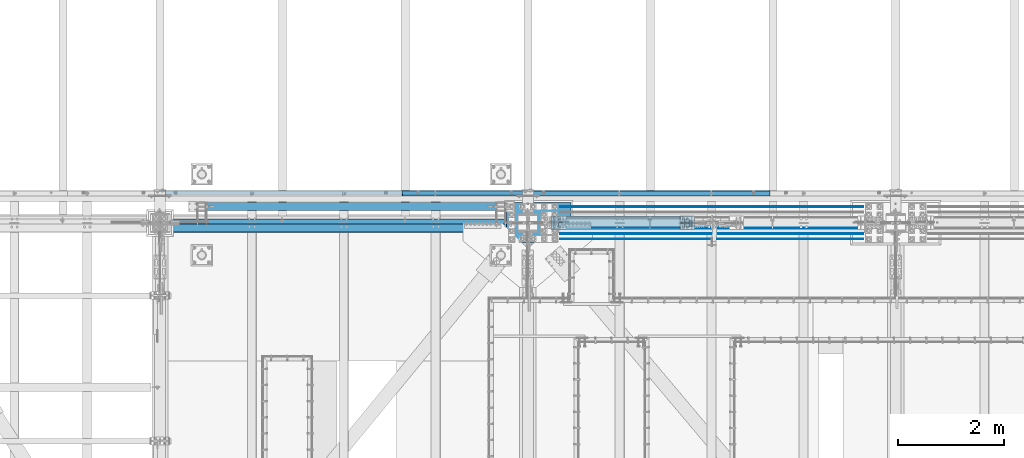
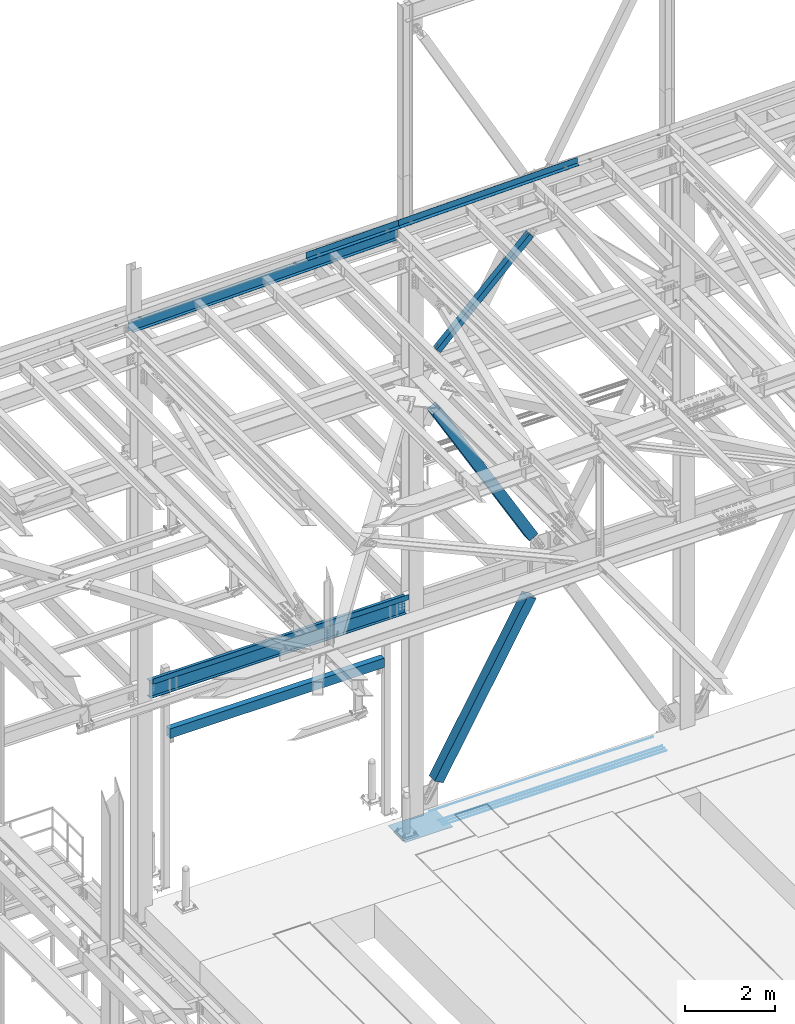
# One storey, part 1914 of 3843: 11 beams, 3 members, 12 elements without a shape of their own.
"""IFC2X3 building model written with IfcOpenShell, lengths in millimetres."""

from ifc_helpers import new_model, si_unit, frame, origin_with_axes, place, context, subcontext, project, spatial, faceted_brep, material, type_object, element, aggregate, save


model = new_model("IFC2X3")

# Units and contexts
model_context = context("Model", 3, precision=1e-05, world=origin_with_axes())
body_context = subcontext(model_context, "Body", "Model", "MODEL_VIEW")
ifc_project = project(units=[si_unit("LENGTHUNIT", "METRE", prefix="MILLI"), si_unit("AREAUNIT", "SQUARE_METRE"), si_unit("VOLUMEUNIT", "CUBIC_METRE"), si_unit("MASSUNIT", "GRAM", prefix="KILO"), si_unit("TIMEUNIT", "SECOND"), si_unit("PLANEANGLEUNIT", "RADIAN"), si_unit("SOLIDANGLEUNIT", "STERADIAN"), si_unit("THERMODYNAMICTEMPERATUREUNIT", "DEGREE_CELSIUS"), si_unit("LUMINOUSINTENSITYUNIT", "LUMEN")], contexts=[model_context])

# Site, building, storey
site_placement = place(None, origin_with_axes())
site = spatial("IfcSite", under=ifc_project, at=site_placement, CompositionType="ELEMENT")
building_placement = place(site_placement, origin_with_axes())
building = spatial("IfcBuilding", under=site, at=building_placement, Name="Undefined", CompositionType="ELEMENT")
storey_placement = place(building_placement, origin_with_axes())
storey = spatial("IfcBuildingStorey", under=building, at=storey_placement, Name="Undefined", CompositionType="ELEMENT", Elevation=0.0)

# Assembly, beam
assembly_1_placement = place(storey_placement, origin_with_axes())
assembly_1 = element("IfcElementAssembly", 1, at=assembly_1_placement, inside=storey, Name="CHANNEL", AssemblyPlace="NOTDEFINED", PredefinedType="RIGID_FRAME")
ifc_material_1 = material(Name="STEEL/A572-50")
beam_type_1 = type_object("IfcBeamType", Name="C12X20.7", PredefinedType="NOTDEFINED")
beam_1_placement = place(assembly_1_placement, frame((42059.0421041034, 92786.1999994988, 45693.1643226337), z_axis=(-0.0211520980073474, 0.0, 0.999776269347241), x_axis=(0.999776270257024, 0.0, 0.0211520550054619)))
beam_1 = element("IfcBeam", 2, at=beam_1_placement, type_object=beam_type_1, material=ifc_material_1, Name="CHANNEL", ObjectType="C12X20.7", context=body_context, shape_type="Brep", body=[
    faceted_brep([(15.8750506456854, 30.1625000000058, -127.000000023756), (15.8750003662499, 38.1000000000058, -127.000000023749), (85.725000532555, 38.1000000000058, -127.000000023691), (85.725000532555, 30.1625000000058, -127.000000023691), (90.5850800505723, 38.1000000000058, -127.966729946267), (90.5850800505723, 30.1625000000058, -127.966729946267), (94.7052565187187, 38.1000000000058, -130.719743846734), (94.7052565187187, 30.1625000000058, -130.719743846734), (97.4582704191853, 38.1000000000058, -134.839920314858), (97.458270419178, 30.1625000000058, -134.674927499669), (98.4250003417692, 1.00112811196595e-06, -139.699999832876), (98.4250003417692, 38.1000000000058, -139.699999832876), (98.4250003417837, 38.1000000000058, -152.399999999638), (98.4250003417837, -38.1000000000058, -152.399999999638), (98.4250003417765, -38.1000000000058, -146.047459999652), (6837.32783496162, -38.1000000000058, 146.04746000663), (6837.32783496162, -38.1000000000058, 152.400000006615), (98.4250003414782, -38.1000000000058, 152.399999999863), (98.4250003414927, -38.1000000000058, 146.047459999871), (6837.32783496162, 38.1000000000058, 152.400000006615), (98.4250003414782, 38.1000000000058, 152.399999999863), (85.7250005323076, 30.1625000000058, 126.99999997508), (85.7250005323076, 38.1000000000058, 126.99999997508), (15.8750006201954, 38.1000000000058, 126.999999975014), (15.8750508996382, 30.1625000000058, 126.999999975007), (90.5850800503176, 30.1625000000058, 127.966729897671), (90.5850800503176, 38.1000000000058, 127.966729897671), (94.7052565184495, 30.1625000000058, 130.719743798138), (94.7052565184495, 38.1000000000058, 130.719743798138), (97.4582704189161, 30.1625000000058, 134.674927499887), (97.4582704189233, 38.1000000000058, 134.839920266269), (98.4250003414927, 1.29402906168252e-06, 139.699999784301), (98.4250003414927, 38.1000000000058, 139.699999784301), (6838.29456488421, 30.1625000000058, 134.67492750664), (6837.32783496162, -5.28016244061291e-07, 139.700000094606), (6837.32783496162, 38.1000000000058, 139.700000094606), (6838.29456488421, 38.1000000000058, 134.839920576582), (6841.04757878468, 30.1625000000058, 130.71974410845), (6841.04757878468, 38.1000000000058, 130.71974410845), (6845.16775525282, 30.1625000000058, 127.966730207998), (6845.16775525282, 38.1000000000058, 127.966730207998), (6850.02783477084, 30.1625000000058, 127.000000285407), (6850.02783477084, 38.1000000000058, 127.000000285407), (6919.87685585659, 30.1625000000058, 127.000000285479), (6919.87674203124, 38.1000000000058, 127.000000285479), (6919.87685579311, 30.1625000000058, 114.299999821429), (6919.87685464037, 30.1625000000058, -116.300000173804), (6919.87685458687, 30.1625000000058, -126.999999713284), (6919.87674076154, 38.1000000000058, -126.999999713284), (6850.02783477111, 30.1625000000058, -126.999999713356), (6850.02783477111, 38.1000000000058, -126.999999713356), (6845.16775525308, 30.1625000000058, -127.96672963594), (6845.16775525308, 38.1000000000058, -127.96672963594), (6841.04757878496, 30.1625000000058, -130.719743536414), (6841.04757878496, 38.1000000000058, -130.719743536414), (6838.29456488449, 30.1625000000058, -134.674927492924), (6838.29456488449, 38.1000000000058, -134.839920004546), (6837.32783496191, 2.82315886579454e-06, -139.699999522578), (6837.32783496191, 38.1000000000058, -139.699999522578), (6837.32783496192, -38.1000000000058, -146.0474599929), (6837.32783496193, -38.1000000000058, -152.399999992886), (6837.32783496193, 38.1000000000058, -152.399999992886), (15.8750506563883, 30.1625000000058, -116.299999981951), (15.8750508869343, 30.1625000000058, 114.300000016628)], [[[0, 1, 2, 3]], [[3, 2, 4, 5]], [[5, 4, 6, 7]], [[7, 6, 8, 9]], [[10, 11, 12, 13, 14]], [[9, 8, 11, 10]], [[15, 16, 17, 18]], [[16, 19, 20, 17]], [[21, 22, 23, 24]], [[25, 26, 22, 21]], [[27, 28, 26, 25]], [[29, 30, 28, 27]], [[31, 32, 30, 29]], [[17, 20, 32, 31, 18]], [[29, 33, 34, 15, 18, 31]], [[16, 15, 34, 35, 19]], [[33, 36, 35, 34]], [[37, 38, 36, 33]], [[39, 40, 38, 37]], [[41, 42, 40, 39]], [[43, 44, 42, 41]], [[44, 43, 45, 46, 47, 48]], [[47, 49, 50, 48]], [[51, 52, 50, 49]], [[53, 54, 52, 51]], [[55, 56, 54, 53]], [[57, 58, 56, 55]], [[59, 60, 61, 58, 57]], [[60, 59, 14, 13]], [[61, 60, 13, 12]], [[6, 4, 2, 1, 23, 22, 26, 28, 30, 32, 20, 19, 35, 36, 38, 40, 42, 44, 48, 50, 52, 54, 56, 58, 61, 12, 11, 8]], [[62, 63, 24, 23, 1, 0]], [[55, 53, 51, 49, 47, 46, 45, 43, 41, 39, 37, 33, 29, 27, 25, 21, 24, 63, 62, 0, 3, 5, 7, 9]], [[59, 57, 55, 9, 10, 14]]]),
])

assembly_2_placement = place(storey_placement, origin_with_axes())
assembly_2 = element("IfcElementAssembly", 3, at=assembly_2_placement, inside=storey, Name="REBAR", AssemblyPlace="NOTDEFINED", PredefinedType="RIGID_FRAME")
ifc_material_2 = material(Name="STEEL/A706-60")
beam_type_2 = type_object("IfcBeamType", Name="#10 REBAR", PredefinedType="NOTDEFINED")
beam_2_placement = place(assembly_2_placement, frame((55321.2176583778, 91909.900012207, 30157.7375195987), z_axis=(-0.00222221699971851, 0.0, 0.999997530872755), x_axis=(-0.999997530872755, 0.0, -0.00222221699971722)))
beam_2 = element("IfcBeam", 4, at=beam_2_placement, type_object=beam_type_2, material=ifc_material_2, Name="REBAR", ObjectType="#10 REBAR", context=body_context, shape_type="Brep", body=[
    faceted_brep([(0.0, -7.9375, 0.0), (0.0, -5.61266007566883, -5.61266007566883), (5715.0141794653, -5.61266007566883, -5.61266008274833), (5715.0141794653, -7.9375, -7.09405867382884e-09), (0.0, 0.0, -7.9375), (5715.01417946529, 0.0, -7.93750000707951), (0.0, 5.61266007566883, -5.61266007566883), (5715.0141794653, 5.61266007566883, -5.61266008274833), (0.0, 7.9375, 0.0), (5715.0141794653, 7.9375, -7.09405867382884e-09), (0.0, 5.61266007566883, 5.61266007566883), (5715.0141794653, 5.61266007566883, 5.61266006856386), (0.0, 0.0, 7.9375), (5715.01417946531, 0.0, 7.93749999289503), (0.0, -5.61266007566883, 5.61266007566883), (5715.0141794653, -5.61266007566883, 5.61266006856386)], [[[0, 1, 2, 3]], [[1, 4, 5, 2]], [[4, 6, 7, 5]], [[6, 8, 9, 7]], [[8, 10, 11, 9]], [[10, 12, 13, 11]], [[12, 14, 15, 13]], [[14, 0, 3, 15]], [[5, 7, 9, 11, 13, 15, 3, 2]], [[14, 12, 10, 8, 6, 4, 1, 0]]]),
])
aggregate(assembly_2, [beam_2])

assembly_3_placement = place(storey_placement, origin_with_axes())
assembly_3 = element("IfcElementAssembly", 5, at=assembly_3_placement, inside=storey, Name="REBAR", AssemblyPlace="NOTDEFINED", PredefinedType="RIGID_FRAME")
beam_3_placement = place(assembly_3_placement, frame((55321.2176583778, 92011.500012207, 30157.7375195987), z_axis=(-0.00222221699971851, 0.0, 0.999997530872755), x_axis=(-0.999997530872755, 0.0, -0.00222221699971722)))
beam_3 = element("IfcBeam", 6, at=beam_3_placement, type_object=beam_type_2, material=ifc_material_2, Name="REBAR", ObjectType="#10 REBAR", context=body_context, shape_type="Brep", body=[
    faceted_brep([(0.0, -7.9375, 0.0), (0.0, -5.61266007566883, -5.61266007566883), (5715.0141794653, -5.61266007566883, -5.61266008274833), (5715.0141794653, -7.9375, -7.09405867382884e-09), (0.0, 0.0, -7.9375), (5715.01417946529, 0.0, -7.93750000707951), (0.0, 5.61266007566883, -5.61266007566883), (5715.0141794653, 5.61266007566883, -5.61266008274833), (0.0, 7.9375, 0.0), (5715.0141794653, 7.9375, -7.09405867382884e-09), (0.0, 5.61266007566883, 5.61266007566883), (5715.0141794653, 5.61266007566883, 5.61266006856386), (0.0, 0.0, 7.9375), (5715.01417946531, 0.0, 7.93749999289503), (0.0, -5.61266007566883, 5.61266007566883), (5715.0141794653, -5.61266007566883, 5.61266006856386)], [[[0, 1, 2, 3]], [[1, 4, 5, 2]], [[4, 6, 7, 5]], [[6, 8, 9, 7]], [[8, 10, 11, 9]], [[10, 12, 13, 11]], [[12, 14, 15, 13]], [[14, 0, 3, 15]], [[5, 7, 9, 11, 13, 15, 3, 2]], [[14, 12, 10, 8, 6, 4, 1, 0]]]),
])
aggregate(assembly_3, [beam_3])

assembly_4_placement = place(storey_placement, origin_with_axes())
assembly_4 = element("IfcElementAssembly", 7, at=assembly_4_placement, inside=storey, Name="REBAR", AssemblyPlace="NOTDEFINED", PredefinedType="RIGID_FRAME")
beam_4_placement = place(assembly_4_placement, frame((55321.2176583778, 92113.100012207, 30157.7375195987), z_axis=(-0.00222221699971851, 0.0, 0.999997530872755), x_axis=(-0.999997530872755, 0.0, -0.00222221699971722)))
beam_4 = element("IfcBeam", 8, at=beam_4_placement, type_object=beam_type_2, material=ifc_material_2, Name="REBAR", ObjectType="#10 REBAR", context=body_context, shape_type="Brep", body=[
    faceted_brep([(0.0, -7.9375, 0.0), (0.0, -5.61266007566883, -5.61266007566883), (5715.0141794653, -5.61266007566883, -5.61266008274833), (5715.0141794653, -7.9375, -7.09405867382884e-09), (0.0, 0.0, -7.9375), (5715.01417946529, 0.0, -7.93750000707951), (0.0, 5.61266007566883, -5.61266007566883), (5715.0141794653, 5.61266007566883, -5.61266008274833), (0.0, 7.9375, 0.0), (5715.0141794653, 7.9375, -7.09405867382884e-09), (0.0, 5.61266007566883, 5.61266007566883), (5715.0141794653, 5.61266007566883, 5.61266006856386), (0.0, 0.0, 7.9375), (5715.01417946531, 0.0, 7.93749999289503), (0.0, -5.61266007566883, 5.61266007566883), (5715.0141794653, -5.61266007566883, 5.61266006856386)], [[[0, 1, 2, 3]], [[1, 4, 5, 2]], [[4, 6, 7, 5]], [[6, 8, 9, 7]], [[8, 10, 11, 9]], [[10, 12, 13, 11]], [[12, 14, 15, 13]], [[14, 0, 3, 15]], [[5, 7, 9, 11, 13, 15, 3, 2]], [[14, 12, 10, 8, 6, 4, 1, 0]]]),
])
aggregate(assembly_4, [beam_4])

assembly_5_placement = place(storey_placement, origin_with_axes())
assembly_5 = element("IfcElementAssembly", 9, at=assembly_5_placement, inside=storey, Name="REBAR", AssemblyPlace="NOTDEFINED", PredefinedType="RIGID_FRAME")
beam_5_placement = place(assembly_5_placement, frame((55321.2176583778, 92519.500012207, 30157.7375195987), z_axis=(-0.00222221699971851, 0.0, 0.999997530872755), x_axis=(-0.999997530872755, 0.0, -0.00222221699971722)))
beam_5 = element("IfcBeam", 10, at=beam_5_placement, type_object=beam_type_2, material=ifc_material_2, Name="REBAR", ObjectType="#10 REBAR", context=body_context, shape_type="Brep", body=[
    faceted_brep([(0.0, -7.9375, 0.0), (0.0, -5.61266007566883, -5.61266007566883), (5715.0141794653, -5.61266007566883, -5.61266008274833), (5715.0141794653, -7.9375, -7.09405867382884e-09), (0.0, 0.0, -7.9375), (5715.01417946529, 0.0, -7.93750000707951), (0.0, 5.61266007566883, -5.61266007566883), (5715.0141794653, 5.61266007566883, -5.61266008274833), (0.0, 7.9375, 0.0), (5715.0141794653, 7.9375, -7.09405867382884e-09), (0.0, 5.61266007566883, 5.61266007566883), (5715.0141794653, 5.61266007566883, 5.61266006856386), (0.0, 0.0, 7.9375), (5715.01417946531, 0.0, 7.93749999289503), (0.0, -5.61266007566883, 5.61266007566883), (5715.0141794653, -5.61266007566883, 5.61266006856386)], [[[0, 1, 2, 3]], [[1, 4, 5, 2]], [[4, 6, 7, 5]], [[6, 8, 9, 7]], [[8, 10, 11, 9]], [[10, 12, 13, 11]], [[12, 14, 15, 13]], [[14, 0, 3, 15]], [[5, 7, 9, 11, 13, 15, 3, 2]], [[14, 12, 10, 8, 6, 4, 1, 0]]]),
])
aggregate(assembly_5, [beam_5])

# Beam
ifc_material_3 = material(Name="STEEL/A36")
beam_type_3 = type_object("IfcBeamType", PredefinedType="NOTDEFINED")
beam_6_placement = place(assembly_1_placement, frame((47808.7635730056, 92722.6999766364, 45970.4200253978), z_axis=(0.999776270257024, 0.0, 0.0211520550054619), x_axis=(0.0, 1.0, 0.0)))
beam_6 = element("IfcBeam", 11, at=beam_6_placement, type_object=beam_type_3, material=ifc_material_3, Name="BENT_PLATE", context=body_context, shape_type="Brep", body=[
    faceted_brep([(9.31322574615479e-10, 5.47515810467303e-08, -1181.89399999808), (-5.38420863449574e-10, 3.17499999882421, -1178.71900003228), (95.2499985702016, 3.17500004347676, -1178.71900003266), (98.4249985454371, 1.00902980193496e-07, -1181.89399999846), (95.2499985053, 161.925001484902, -1178.71900003352), (98.4249984792696, 161.925001486248, -1181.89399999885), (95.2499985716568, 3.17500004584144, 1181.89399999772), (95.2499985032919, 161.925001490621, 1181.89399999733), (2.40106601268053e-09, -3.17500000117434, -1181.89399999807), (5.0931703299284e-10, -3.17499999881693, 1181.8939999981), (-2.43016984313726e-09, 3.17500000118162, 1181.89399999809), (101.599998572856, -3.17499995353865, -1181.89399999847), (101.599998574326, -3.17499995117396, 1181.89399999771), (101.599998503283, 161.925001493335, 1181.89399999731), (101.59999850532, 161.925001487602, -1181.89399999887)], [[[0, 1, 2, 3]], [[3, 2, 4, 5]], [[6, 7, 4, 2]], [[8, 9, 10, 1, 0]], [[10, 6, 2, 1]], [[9, 8, 11, 12]], [[6, 10, 9, 12, 13, 7]], [[12, 11, 14, 13]], [[14, 11, 8, 0, 3, 5]], [[7, 13, 14, 5, 4]]]),
])

aggregate(assembly_1, [beam_6, beam_1])

# Assembly, beam
assembly_6_placement = place(storey_placement, origin_with_axes())
assembly_6 = element("IfcElementAssembly", 12, at=assembly_6_placement, inside=storey, Name="CHANNEL", AssemblyPlace="NOTDEFINED", PredefinedType="RIGID_FRAME")
beam_7_placement = place(assembly_6_placement, frame((51275.4399130485, 92722.6999533718, 46043.7639123841), z_axis=(0.999776270257024, 0.0, 0.0211520550054619), x_axis=(0.0, 1.0, 0.0)))
beam_7 = element("IfcBeam", 13, at=beam_7_placement, type_object=beam_type_3, material=ifc_material_3, Name="BENT_PLATE", context=body_context, shape_type="Brep", body=[
    faceted_brep([(0.0, 0.0, -2286.0), (3.49245965480804e-10, 3.17499999771098, -2282.82500002157), (95.2499986609328, 3.17500004237809, -2282.82500002194), (98.4249986544455, 9.08548827283084e-08, -2285.99999999666), (95.249998597661, 161.925001390824, -2282.82500002276), (98.4249985899223, 161.92500139217, -2285.99999999706), (95.2499986633193, 3.17500004695466, 2285.99999999594), (95.2499985934701, 161.925001402509, 2285.99999999556), (5.82076609134674e-11, -3.17499999999563, -2286.0), (5.82076609134674e-11, -3.17499999999563, 2286.0), (-4.36557456851006e-11, 3.17499999998836, 2286.0), (101.599998662903, -3.17499995464459, -2285.99999999667), (101.600001545667, -3.17499906016019, 2285.99999999734), (101.599998593476, 161.925001405216, 2285.99999999553), (101.599998596852, 161.925001394004, -2285.99999999707)], [[[0, 1, 2, 3]], [[3, 2, 4, 5]], [[6, 7, 4, 2]], [[8, 9, 10, 1, 0]], [[10, 6, 2, 1]], [[9, 8, 11, 12]], [[6, 10, 9, 12, 13, 7]], [[12, 11, 14, 13]], [[14, 11, 8, 0, 3, 5]], [[7, 13, 14, 5, 4]]]),
])
aggregate(assembly_6, [beam_7])

# Assembly, member
assembly_7_placement = place(storey_placement, origin_with_axes())
assembly_7 = element("IfcElementAssembly", 14, at=assembly_7_placement, inside=storey, Name="None", AssemblyPlace="NOTDEFINED", PredefinedType="RIGID_FRAME")
ifc_material_4 = material(Name="STEEL/A992")
member_type_1 = type_object("IfcMemberType", Name="HSS10X10X1/4", PredefinedType="NOTDEFINED")
member_1_placement = place(assembly_7_placement, frame((49603.1874731603, 92214.7, 31198.3503371165), z_axis=(0.0, -1.0, 0.0), x_axis=(0.496236812004375, 0.0, 0.868187207007645)))
member_1 = element("IfcMember", 15, at=member_1_placement, type_object=member_type_1, material=ifc_material_4, Name="None", ObjectType="HSS10X10X1/4", context=body_context, shape_type="Brep", body=[
    faceted_brep([(2.00088834390044e-10, 120.650000000089, -120.649999999994), (-2.03726813197136e-10, -120.650000000081, -120.649999999994), (4781.54999999434, -120.649999998248, -120.649999999994), (4781.54999999471, 120.650000000955, -120.649999999994), (-2.03726813197136e-10, -120.650000000081, 120.649999999994), (4781.54999999434, -120.649999998248, 120.649999999994), (2.00088834390044e-10, 120.650000000089, 120.649999999994), (4781.54999999471, 120.650000000955, 120.649999999994), (2.16459739021957e-10, 127.000000000087, -127.0), (2.16459739021957e-10, 127.000000000087, 127.0), (4781.54999999471, 127.000000000939, 127.0), (4781.54999999471, 127.000000000939, -127.0), (-2.14640749618411e-10, -127.00000000008, 127.0), (4781.54999999432, -126.999999998225, 127.0), (-2.14640749618411e-10, -127.00000000008, -127.0), (4781.54999999432, -126.999999998225, -127.0)], [[[0, 1, 2, 3]], [[1, 4, 5, 2]], [[4, 6, 7, 5]], [[6, 0, 3, 7]], [[8, 9, 10, 11]], [[9, 12, 13, 10]], [[12, 14, 15, 13]], [[14, 8, 11, 15]], [[13, 15, 11, 10], [5, 7, 3, 2]], [[14, 12, 9, 8], [6, 4, 1, 0]]]),
])
aggregate(assembly_7, [member_1])

assembly_8_placement = place(storey_placement, origin_with_axes())
assembly_8 = element("IfcElementAssembly", 16, at=assembly_8_placement, inside=storey, Name="None", AssemblyPlace="NOTDEFINED", PredefinedType="RIGID_FRAME")
member_2_placement = place(assembly_8_placement, frame((52024.9587129261, 92214.7, 36961.4938630287), z_axis=(0.0, 1.0, 0.0), x_axis=(-0.500674758933455, 0.0, 0.865635480884955)))
member_2 = element("IfcMember", 17, at=member_2_placement, type_object=member_type_1, material=ifc_material_4, Name="None", ObjectType="HSS10X10X1/4", context=body_context, shape_type="Brep", body=[
    faceted_brep([(2.00088834390044e-10, 120.650000000089, -120.649999999994), (-2.03726813197136e-10, -120.650000000081, -120.649999999994), (4946.65074268766, -120.650000011752, -120.649999999994), (4946.65074268823, 120.649999988462, -120.649999999994), (-2.03726813197136e-10, -120.650000000081, 120.649999999994), (4946.65074268766, -120.650000011752, 120.649999999994), (2.00088834390044e-10, 120.650000000089, 120.649999999994), (4946.65074268823, 120.649999988462, 120.649999999994), (2.16459739021957e-10, 127.000000000087, -127.0), (2.16459739021957e-10, 127.000000000087, 127.0), (4946.65074268825, 126.999999988468, 127.0), (4946.65074268825, 126.999999988468, -127.0), (-2.14640749618411e-10, -127.00000000008, 127.0), (4946.65074268765, -127.000000011751, 127.0), (-2.14640749618411e-10, -127.00000000008, -127.0), (4946.65074268765, -127.000000011751, -127.0)], [[[0, 1, 2, 3]], [[1, 4, 5, 2]], [[4, 6, 7, 5]], [[6, 0, 3, 7]], [[8, 9, 10, 11]], [[9, 12, 13, 10]], [[12, 14, 15, 13]], [[14, 8, 11, 15]], [[13, 15, 11, 10], [5, 7, 3, 2]], [[14, 12, 9, 8], [6, 4, 1, 0]]]),
])
aggregate(assembly_8, [member_2])

# Assembly, beam
assembly_9_placement = place(storey_placement, origin_with_axes())
assembly_9 = element("IfcElementAssembly", 18, at=assembly_9_placement, inside=storey, Name="BEAM", AssemblyPlace="NOTDEFINED", PredefinedType="RIGID_FRAME")
beam_type_4 = type_object("IfcBeamType", PredefinedType="NOTDEFINED")
beam_8_placement = place(assembly_9_placement, frame((45529.5, 92189.3, 36439.475), z_axis=(-1.0, 0.0, 0.0), x_axis=(0.0, -1.0, 0.0)))
beam_8 = element("IfcBeam", 19, at=beam_8_placement, type_object=beam_type_4, material=ifc_material_3, Name="BENT_PLATE", context=body_context, shape_type="Brep", body=[
    faceted_brep([(0.0, -3.17500000000291, -3270.25), (0.0, -3.17500000000291, 3270.25), (0.0, 3.17500000000291, 3270.25), (0.0, 3.17500000000291, -3270.25), (146.049993896479, 3.17500000000291, 3270.25), (146.049993896479, 3.17500000000291, -3270.25), (152.399993896484, -3.17500000000291, -3270.25), (152.399993896484, -3.17500000000291, 3270.25), (146.049993896479, 136.524996948239, 3270.25), (146.049993896479, 136.524996948239, -3270.25), (152.399993896484, 136.524996948239, 3270.25), (152.399993896484, 136.524996948239, -3270.25)], [[[0, 1, 2, 3]], [[3, 2, 4, 5]], [[1, 0, 6, 7]], [[5, 4, 8, 9]], [[4, 2, 1, 7, 10, 8]], [[7, 6, 11, 10]], [[6, 0, 3, 5, 9, 11]], [[10, 11, 9, 8]]]),
])

# Assembly, member
assembly_10_placement = place(storey_placement, origin_with_axes())
assembly_10 = element("IfcElementAssembly", 20, at=assembly_10_placement, inside=storey, AssemblyPlace="NOTDEFINED", PredefinedType="RIGID_FRAME")
ifc_material_5 = material()
member_type_2 = type_object("IfcMemberType", Name="HSS6X6X3/8", PredefinedType="NOTDEFINED")
member_3_placement = place(assembly_10_placement, frame((48996.6, 92214.6999998457, 42197.3375), z_axis=(0.694768099271008, 0.0, -0.719233820280547), x_axis=(0.71923382028056, 0.0, 0.694768099270995)))
member_3 = element("IfcMember", 21, at=member_3_placement, type_object=member_type_2, material=ifc_material_5, ObjectType="HSS6X6X3/8", context=body_context, shape_type="Brep", body=[
    faceted_brep([(4176.83224805473, 7.9375, 76.1999999894979), (4076.81974805323, 7.9375, 76.1999999897489), (4076.81974805322, 7.9375, 66.6749999897293), (4176.83224805471, 7.9375, 66.6749999894782), (4073.78219830881, 7.33329378931376, 76.1999999897598), (4073.7821983088, 7.33329378931376, 66.6749999897329), (4071.20708797753, 5.61266007566883, 76.1999999897707), (4071.20708797751, 5.61266007566883, 66.6749999897438), (4069.48645426388, 3.0375497444038, 76.1999999897744), (4069.48645426386, 3.0375497444038, 66.6749999897438), (4068.88224805319, 0.0, 76.1999999897671), (4068.88224805316, 0.0, 66.6749999897547), (4069.48645426388, -3.0375497444038, 76.1999999897744), (4069.48645426386, -3.0375497444038, 66.6749999897438), (4071.20708797753, -5.61266007566883, 76.1999999897707), (4071.20708797751, -5.61266007566883, 66.6749999897438), (4073.78219830881, -7.33329378931376, 76.1999999897598), (4073.7821983088, -7.33329378931376, 66.6749999897329), (4076.81974805323, -7.9375, 76.1999999897489), (4076.81974805322, -7.9375, 66.6749999897293), (4176.83224805473, -7.9375, 76.1999999894979), (4176.83224805471, -7.9375, 66.6749999894782), (4176.83224805473, 7.9375, -66.6750000108113), (4076.81974805288, 7.9375, -66.675000010564), (4076.81974805285, 7.9375, -76.2000000105836), (4176.83224805471, 7.9375, -76.2000000108419), (4073.78219830847, 7.33329378931376, -66.675000010553), (4073.78219830844, 7.33329378931376, -76.20000001058), (4071.20708797717, 5.61266007566883, -66.6750000105421), (4071.20708797714, 5.61266007566883, -76.2000000105691), (4069.48645426351, 3.0375497444038, -66.6750000105458), (4069.4864542635, 3.0375497444038, -76.2000000105654), (4068.88224805283, 0.0, -66.6750000105458), (4068.8822480528, 0.0, -76.2000000105654), (4069.48645426351, -3.0375497444038, -66.6750000105458), (4069.4864542635, -3.0375497444038, -76.2000000105654), (4071.20708797717, -5.61266007566883, -66.6750000105421), (4071.20708797714, -5.61266007566883, -76.2000000105691), (4073.78219830847, -7.33329378931376, -66.675000010553), (4073.78219830844, -7.33329378931376, -76.20000001058), (4076.81974805288, -7.9375, -66.675000010564), (4076.81974805285, -7.9375, -76.2000000105836), (4176.83224805473, -7.9375, -66.6750000108113), (4176.83224805471, -7.9375, -76.2000000108419), (869.196469576338, 66.6750000000029, 66.6749999979256), (869.196469576338, 66.6750000000029, -66.675000002364), (4176.83224805473, 66.6750000000029, -66.6750000108113), (4176.83224805471, 66.6750000000029, 66.6749999894782), (4176.83224805471, -66.6750000000029, 66.6749999894782), (869.196469576338, -66.6750000000029, 66.6749999979256), (869.196469576338, -20.6374999999971, 66.6749999979256), (969.208969580803, -20.6374999999971, 66.6749999976746), (972.246519325228, -20.0332937893108, 66.674999997671), (974.821629656501, -18.3126600756659, 66.6749999976601), (976.542263370167, -15.7375497444009, 66.6749999976601), (977.146469580861, -12.6999999999971, 66.6749999976564), (976.542263370167, -9.66245025559328, 66.6749999976601), (974.821629656501, -7.08733992432826, 66.6749999976601), (972.246519325228, -5.36670621068333, 66.674999997671), (969.208969580803, -4.76249999999709, 66.6749999976746), (869.196469576338, -4.76249999999709, 66.6749999979256), (869.196469576338, -66.6750000000029, -66.675000002364), (4176.83224805473, -66.6750000000029, -66.6750000108113), (869.196469576338, -4.76249999999709, -66.675000002364), (969.208969580461, -4.76249999999709, -66.675000002615), (972.246519324886, -5.36670621068333, -66.6750000026295), (974.821629656166, -7.08733992432826, -66.6750000026295), (976.542263369825, -9.66245025559328, -66.6750000026332), (977.146469580512, -12.6999999999971, -66.6750000026404), (976.542263369825, -15.7375497444009, -66.6750000026332), (974.821629656166, -18.3126600756659, -66.6750000026295), (972.246519324886, -20.0332937893108, -66.6750000026295), (969.208969580461, -20.6374999999971, -66.675000002615), (869.196469576338, -20.6374999999971, -66.675000002364), (869.196469576331, -4.76249999999709, -76.20000000238), (969.208969580439, -4.76249999999709, -76.200000002631), (972.246519324857, -5.36670621068333, -76.2000000026419), (974.821629656144, -7.08733992432826, -76.2000000026528), (976.542263369796, -9.66245025559328, -76.2000000026565), (977.14646958049, -12.6999999999971, -76.2000000026565), (976.542263369796, -15.7375497444009, -76.2000000026565), (974.821629656144, -18.3126600756659, -76.2000000026528), (972.246519324857, -20.0332937893108, -76.2000000026419), (969.208969580439, -20.6374999999971, -76.200000002631), (869.196469576331, -20.6374999999971, -76.20000000238), (869.196469576331, -76.1999999999971, -76.20000000238), (869.196469576338, -76.1999999999971, 76.1999999979525), (869.196469576338, -20.6374999999971, 76.1999999979525), (969.208969580832, -20.6374999999971, 76.1999999976942), (972.24651932525, -20.0332937893108, 76.1999999976906), (974.821629656537, -18.3126600756659, 76.1999999976797), (976.542263370182, -15.7375497444009, 76.1999999976797), (977.146469580883, -12.6999999999971, 76.1999999976797), (976.542263370182, -9.66245025559328, 76.1999999976797), (974.821629656537, -7.08733992432826, 76.1999999976797), (972.24651932525, -5.36670621068333, 76.1999999976906), (969.208969580832, -4.76249999999709, 76.1999999976942), (869.196469576338, -4.76249999999709, 76.1999999979525), (869.196469576338, 76.1999999999971, 76.1999999979525), (869.196469576331, 76.1999999999971, -76.20000000238), (4176.83224805473, 76.1999999999971, 76.1999999894979), (4176.83224805471, 76.1999999999971, -76.2000000108419), (4176.83224805471, -76.1999999999971, -76.2000000108419), (4176.83224805473, -76.1999999999971, 76.1999999894979)], [[[0, 1, 2, 3]], [[4, 5, 2, 1]], [[6, 7, 5, 4]], [[8, 9, 7, 6]], [[10, 11, 9, 8]], [[12, 13, 11, 10]], [[14, 15, 13, 12]], [[16, 17, 15, 14]], [[18, 19, 17, 16]], [[20, 21, 19, 18]], [[22, 23, 24, 25]], [[26, 27, 24, 23]], [[28, 29, 27, 26]], [[30, 31, 29, 28]], [[32, 33, 31, 30]], [[34, 35, 33, 32]], [[36, 37, 35, 34]], [[38, 39, 37, 36]], [[40, 41, 39, 38]], [[42, 43, 41, 40]], [[44, 45, 46, 47]], [[48, 49, 50, 51, 52, 53, 54, 55, 56, 57, 58, 59, 60, 44, 47, 3, 2, 5, 7, 9, 11, 13, 15, 17, 19, 21]], [[61, 49, 48, 62]], [[38, 36, 34, 32, 30, 28, 26, 23, 22, 46, 45, 63, 64, 65, 66, 67, 68, 69, 70, 71, 72, 73, 61, 62, 42, 40]], [[63, 74, 75, 64]], [[64, 75, 76, 65]], [[65, 76, 77, 66]], [[66, 77, 78, 67]], [[67, 78, 79, 68]], [[68, 79, 80, 69]], [[69, 80, 81, 70]], [[70, 81, 82, 71]], [[71, 82, 83, 72]], [[72, 83, 84, 73]], [[49, 61, 73, 84, 85, 86, 87, 50]], [[88, 51, 50, 87]], [[89, 52, 51, 88]], [[90, 53, 52, 89]], [[91, 54, 53, 90]], [[92, 55, 54, 91]], [[93, 56, 55, 92]], [[94, 57, 56, 93]], [[95, 58, 57, 94]], [[96, 59, 58, 95]], [[97, 60, 59, 96]], [[98, 99, 74, 63, 45, 44, 60, 97]], [[99, 98, 100, 101]], [[47, 46, 22, 25, 101, 100, 0, 3]], [[102, 85, 84, 83, 82, 81, 80, 79, 78, 77, 76, 75, 74, 99, 101, 25, 24, 27, 29, 31, 33, 35, 37, 39, 41, 43]], [[86, 85, 102, 103]], [[16, 14, 12, 10, 8, 6, 4, 1, 0, 100, 98, 97, 96, 95, 94, 93, 92, 91, 90, 89, 88, 87, 86, 103, 20, 18]], [[103, 102, 43, 42, 62, 48, 21, 20]]]),
])
aggregate(assembly_10, [member_3])

# Assembly, beam
assembly_11_placement = place(storey_placement, origin_with_axes())
assembly_11 = element("IfcElementAssembly", 22, at=assembly_11_placement, inside=storey, Name="BEAM", AssemblyPlace="NOTDEFINED", PredefinedType="RIGID_FRAME")
beam_type_5 = type_object("IfcBeamType", Name="HSS10X6X1/4", PredefinedType="NOTDEFINED")
beam_9_placement = place(assembly_11_placement, frame((42849.8, 92519.5, 34620.2000061036), z_axis=(0.0, 0.0, 1.0), x_axis=(1.0, 0.0, 0.0)))
beam_9 = element("IfcBeam", 23, at=beam_9_placement, type_object=beam_type_5, material=ifc_material_5, Name="BEAM", ObjectType="HSS10X6X1/4", context=body_context, shape_type="Brep", body=[
    faceted_brep([(76.2000000000044, 69.8500000000058, -120.650000000001), (76.2000000000044, -69.8500000000058, -120.650000000001), (5562.60000000001, -69.8500000000058, -120.650000000001), (5562.60000000001, 69.8500000000058, -120.650000000001), (76.2000000000044, -69.8500000000058, 120.650000000001), (5562.60000000001, -69.8500000000058, 120.650000000001), (76.2000000000044, 69.8500000000058, 120.650000000001), (5562.60000000001, 69.8500000000058, 120.650000000001), (76.2000000000044, 76.1999999999971, -127.0), (76.2000000000044, 76.1999999999971, 127.0), (5562.60000000001, 76.1999999999971, 127.0), (5562.60000000001, 76.1999999999971, -127.0), (76.2000000000044, -76.1999999999971, 127.0), (5562.60000000001, -76.1999999999971, 127.0), (76.2000000000044, -76.1999999999971, -127.0), (5562.60000000001, -76.1999999999971, -127.0)], [[[0, 1, 2, 3]], [[1, 4, 5, 2]], [[4, 6, 7, 5]], [[6, 0, 3, 7]], [[8, 9, 10, 11]], [[9, 12, 13, 10]], [[12, 14, 15, 13]], [[14, 8, 11, 15]], [[13, 15, 11, 10], [5, 7, 3, 2]], [[14, 12, 9, 8], [6, 4, 1, 0]]]),
])
aggregate(assembly_11, [beam_9])

# Beam
beam_type_6 = type_object("IfcBeamType", Name="W18X40", PredefinedType="NOTDEFINED")
beam_10_placement = place(assembly_9_placement, frame((42062.4, 92214.7, 36209.2875), z_axis=(0.0, 0.0, 1.0), x_axis=(1.0, 0.0, 0.0)))
beam_10 = element("IfcBeam", 24, at=beam_10_placement, type_object=beam_type_6, material=ifc_material_4, Name="BEAM", ObjectType="W18X40", context=body_context, shape_type="Brep", body=[
    faceted_brep([(196.849999999991, -76.1999999999971, -227.012499999997), (196.849999999991, 76.1999999999971, -227.012499999997), (6737.35, 76.1999999999971, -227.012499999997), (6737.35, -76.1999999999971, -227.012499999997), (196.849999999999, -76.2000000000007, -214.3125), (196.849999999999, -3.96875, -214.3125), (196.849999999999, -3.96875, 214.3125), (196.849999999999, -76.2000000000007, 214.3125), (196.849999999991, -76.1999999999971, 227.012499999997), (196.849999999991, 76.1999999999971, 227.012499999997), (196.849999999999, 76.2000000000007, 214.3125), (196.849999999999, 3.96875, 214.3125), (196.849999999991, 3.96875, 196.002499999995), (196.849999999991, 3.96875, -122.977500000001), (196.849999999999, 3.96875, -214.3125), (196.849999999999, 76.2000000000007, -214.3125), (6737.35, -76.1999999999971, -214.3125), (6737.35, -3.96875, -214.3125), (6737.35, -3.96875, 214.3125), (6737.35, -76.1999999999971, 214.3125), (6737.35, -76.1999999999971, 227.012499999997), (6737.35, 76.1999999999971, 227.012499999997), (6737.35, 76.1999999999971, 214.3125), (6737.35, 3.96875, 214.3125), (6737.35, 3.96875, 196.002499999995), (6737.35, 3.96875, -122.977500000001), (6737.35, 3.96875, -214.3125), (6737.35, 76.1999999999971, -214.3125)], [[[0, 1, 2, 3]], [[0, 4, 5, 6, 7, 8, 9, 10, 11, 12, 13, 14, 15, 1]], [[5, 4, 16, 17]], [[6, 5, 17, 18]], [[7, 6, 18, 19]], [[8, 7, 19, 20]], [[9, 8, 20, 21]], [[10, 9, 21, 22]], [[11, 10, 22, 23]], [[14, 13, 12, 11, 23, 24, 25, 26]], [[15, 14, 26, 27]], [[1, 15, 27, 2]], [[26, 25, 24, 23, 22, 21, 20, 19, 18, 17, 16, 3, 2, 27]], [[4, 0, 3, 16]]]),
])

aggregate(assembly_9, [beam_8, beam_10])

# Assembly, beam
assembly_12_placement = place(storey_placement, origin_with_axes())
assembly_12 = element("IfcElementAssembly", 25, at=assembly_12_placement, inside=storey, Name="TEMPLATE", AssemblyPlace="NOTDEFINED", PredefinedType="RIGID_FRAME")
beam_type_7 = type_object("IfcBeamType", PredefinedType="NOTDEFINED")
beam_11_placement = place(assembly_12_placement, frame((49199.8, 91833.7000030518, 30065.6625), z_axis=(-1.0, 0.0, 0.0), x_axis=(0.0, 1.0, 0.0)))
beam_11 = element("IfcBeam", 26, at=beam_11_placement, type_object=beam_type_7, material=ifc_material_1, Name="TEMPLATE", context=body_context, shape_type="Brep", body=[
    faceted_brep([(0.0, 4.76250000000073, -609.599999999999), (0.0, 4.76250000000073, 609.599999999999), (762.00001220702, 4.76250000000073, 609.599999999999), (762.00001220702, 4.76250000000073, -609.599999999999), (0.0, -4.76250000000073, 609.599999999999), (762.00001220702, -4.76250000000073, 609.599999999999), (0.0, -4.76250000000073, -609.599999999999), (762.00001220702, -4.76250000000073, -609.599999999999)], [[[0, 1, 2, 3]], [[1, 4, 5, 2]], [[4, 6, 7, 5]], [[6, 0, 3, 7]], [[5, 7, 3, 2]], [[6, 4, 1, 0]]]),
])
aggregate(assembly_12, [beam_11])

save(model, "model.ifc")
